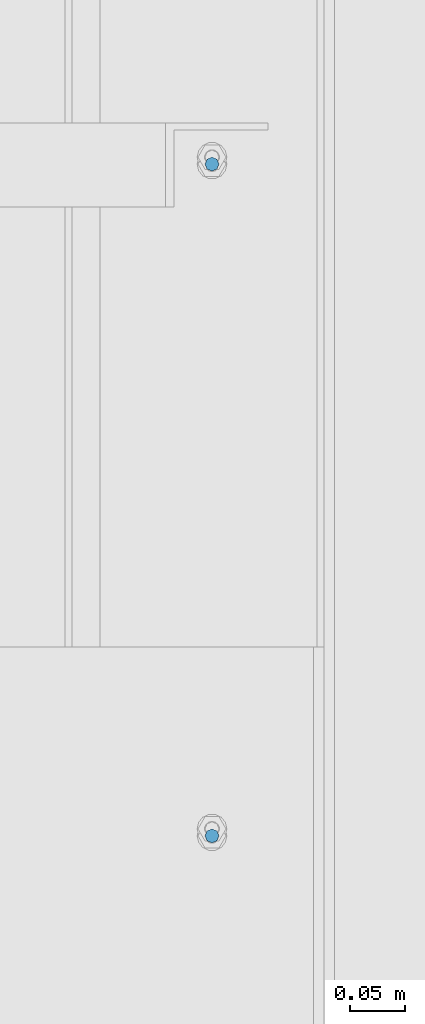
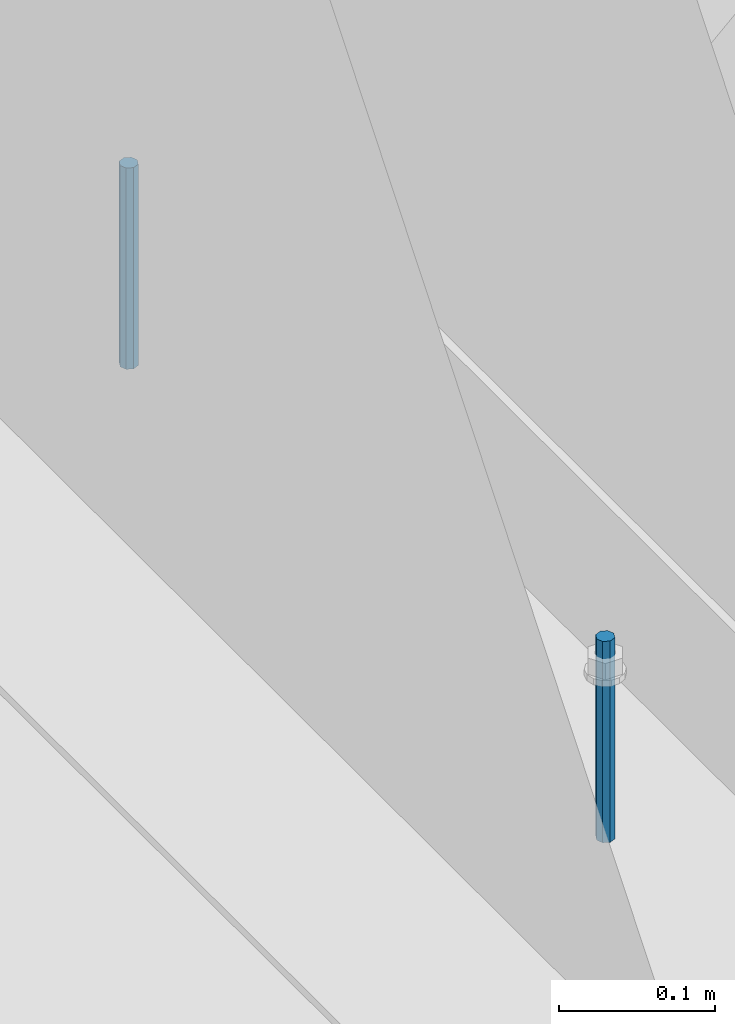
# One storey, part 476 of 1179: 2 columns, 1 element without a shape of its own.
"""IFC2X3 building model written with IfcOpenShell, lengths in millimetres."""

from ifc_helpers import new_model, si_unit, frame, origin_with_axes, place, context, subcontext, project, spatial, faceted_brep, material, type_object, element, aggregate, save


model = new_model("IFC2X3")

# Units and contexts
model_context = context("Model", 3, precision=1e-05, world=origin_with_axes())
body_context = subcontext(model_context, "Body", "Model", "MODEL_VIEW")
ifc_project = project(units=[si_unit("LENGTHUNIT", "METRE", prefix="MILLI"), si_unit("AREAUNIT", "SQUARE_METRE"), si_unit("VOLUMEUNIT", "CUBIC_METRE"), si_unit("MASSUNIT", "GRAM", prefix="KILO"), si_unit("TIMEUNIT", "SECOND"), si_unit("PLANEANGLEUNIT", "RADIAN"), si_unit("SOLIDANGLEUNIT", "STERADIAN"), si_unit("THERMODYNAMICTEMPERATUREUNIT", "DEGREE_CELSIUS"), si_unit("LUMINOUSINTENSITYUNIT", "LUMEN")], contexts=[model_context])

# Site, building, storey
site_placement = place(None, origin_with_axes())
site = spatial("IfcSite", under=ifc_project, at=site_placement, CompositionType="ELEMENT")
building_placement = place(site_placement, origin_with_axes())
building = spatial("IfcBuilding", under=site, at=building_placement, Name="Undefined", CompositionType="ELEMENT")
storey_placement = place(building_placement, origin_with_axes())
storey = spatial("IfcBuildingStorey", under=building, at=storey_placement, Name="Undefined", CompositionType="ELEMENT", Elevation=0.0)

# Assembly, columns
assembly_placement = place(storey_placement, origin_with_axes())
assembly = element("IfcElementAssembly", 1, at=assembly_placement, inside=storey, Name="BEAM", AssemblyPlace="NOTDEFINED", PredefinedType="RIGID_FRAME")
ifc_material = material(Name="STEEL/A307")
column_type = type_object("IfcColumnType", PredefinedType="NOTDEFINED")
column_1_placement = place(assembly_placement, frame((24638.0, 31635.70025, 4108.45), z_axis=(0.0, 1.0, 0.0), x_axis=(0.0, 0.0, 1.0)))
column_1 = element("IfcColumn", 2, at=column_1_placement, type_object=column_type, material=ifc_material, Name="THREADED ROD", context=body_context, shape_type="Brep", body=[
    faceted_brep([(0.0, -6.34999999999854, 0.0), (0.0, -4.49012806053361, -4.49012806053452), (157.162499999999, -4.49012806053361, -4.49012806053361), (157.162499999999, -6.34999999999854, 0.0), (0.0, 0.0, -6.34999999999991), (157.162499999999, 0.0, -6.34999999999854), (0.0, 4.49012806053361, -4.49012806053452), (157.162499999999, 4.49012806053361, -4.49012806053361), (0.0, 6.34999999999854, 0.0), (157.162499999999, 6.34999999999854, 0.0), (0.0, 4.49012806053361, 4.49012806053452), (157.162499999999, 4.49012806053361, 4.49012806053361), (0.0, 0.0, 6.34999999999991), (157.162499999999, 0.0, 6.34999999999854), (0.0, -4.49012806053361, 4.49012806053452), (157.162499999999, -4.49012806053361, 4.49012806053361)], [[[0, 1, 2, 3]], [[1, 4, 5, 2]], [[4, 6, 7, 5]], [[6, 8, 9, 7]], [[8, 10, 11, 9]], [[10, 12, 13, 11]], [[12, 14, 15, 13]], [[14, 0, 3, 15]], [[5, 7, 9, 11, 13, 15, 3, 2]], [[14, 12, 10, 8, 6, 4, 1, 0]]]),
])
column_2_placement = place(assembly_placement, frame((24638.0, 31026.10025, 4108.45), z_axis=(0.0, 1.0, 0.0), x_axis=(0.0, 0.0, 1.0)))
column_2 = element("IfcColumn", 3, at=column_2_placement, type_object=column_type, material=ifc_material, Name="THREADED ROD", context=body_context, shape_type="Brep", body=[
    faceted_brep([(0.0, -6.34999999999854, 0.0), (0.0, -4.49012806053361, -4.49012806053452), (157.162499999999, -4.49012806053361, -4.49012806053361), (157.162499999999, -6.34999999999854, 0.0), (0.0, 0.0, -6.34999999999991), (157.162499999999, 0.0, -6.34999999999854), (0.0, 4.49012806053361, -4.49012806053452), (157.162499999999, 4.49012806053361, -4.49012806053361), (0.0, 6.34999999999854, 0.0), (157.162499999999, 6.34999999999854, 0.0), (0.0, 4.49012806053361, 4.49012806053452), (157.162499999999, 4.49012806053361, 4.49012806053361), (0.0, 0.0, 6.34999999999991), (157.162499999999, 0.0, 6.34999999999854), (0.0, -4.49012806053361, 4.49012806053452), (157.162499999999, -4.49012806053361, 4.49012806053361)], [[[0, 1, 2, 3]], [[1, 4, 5, 2]], [[4, 6, 7, 5]], [[6, 8, 9, 7]], [[8, 10, 11, 9]], [[10, 12, 13, 11]], [[12, 14, 15, 13]], [[14, 0, 3, 15]], [[5, 7, 9, 11, 13, 15, 3, 2]], [[14, 12, 10, 8, 6, 4, 1, 0]]]),
])
aggregate(assembly, [column_1, column_2])

save(model, "model.ifc")
